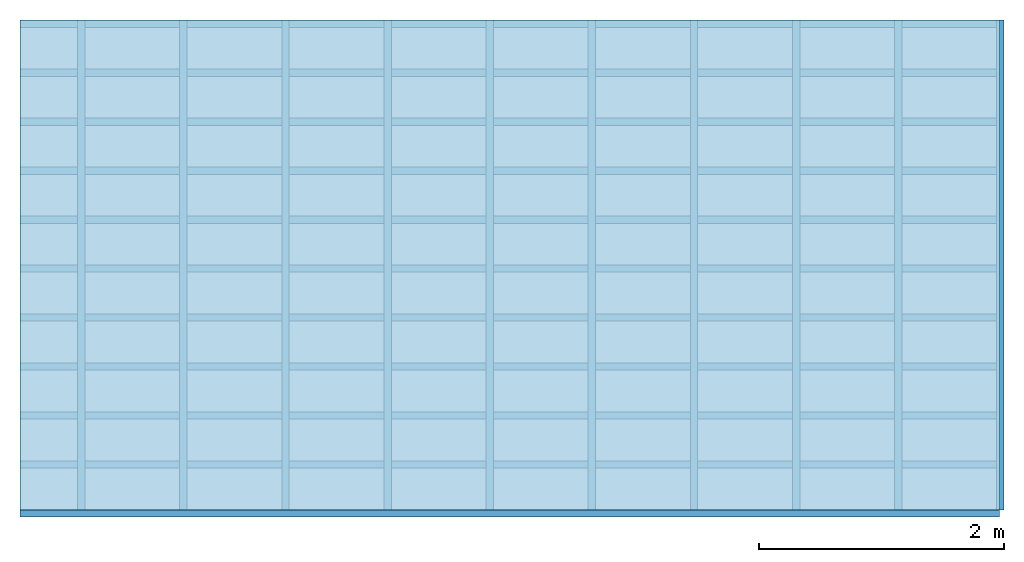
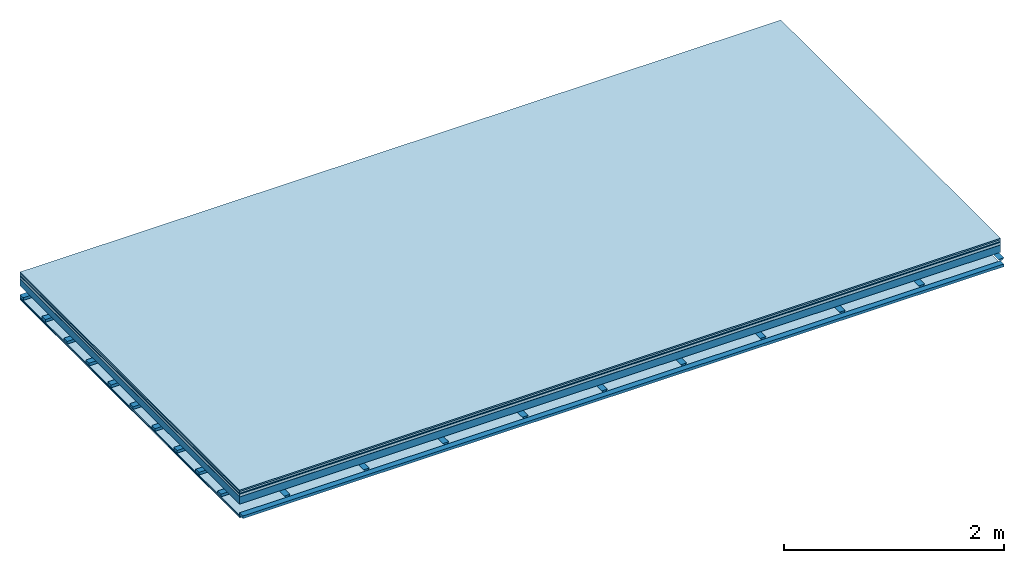
# One storey: 8 plates, 3 members, 1 element without a shape of its own.
"""IFC4 building model written with IfcOpenShell, lengths in metres."""

from ifc_helpers import new_model, si_unit, derived_unit, direction, frame, frame_2d, origin, origin_with_axes, place, context, project, spatial, polyline, rectangle, outline, extrude, material, layer, layer_set, type_object, element, aggregate, save


model = new_model("IFC4")

# Units and contexts
plan_context = context("Plan", 3, precision=1e-05, world=origin(), true_north=direction((0.0, 1.0)))
model_context = context("Model", 3, precision=1e-05, world=origin(), true_north=direction((0.0, 1.0)))
ifc_project = project(units=[si_unit("LENGTHUNIT", "METRE"), derived_unit("SOUNDPRESSUREUNIT", [(si_unit("PRESSUREUNIT", "PASCAL", prefix="MICRO"), 0)]), si_unit("ENERGYUNIT", "JOULE", prefix="MEGA"), si_unit("MASSUNIT", "GRAM", prefix="KILO"), derived_unit("THERMALTRANSMITTANCEUNIT", [(si_unit("POWERUNIT", "WATT"), 1), (si_unit("AREAUNIT", "SQUARE_METRE"), -1), (si_unit("THERMODYNAMICTEMPERATUREUNIT", "KELVIN"), -1)]), derived_unit("AREADENSITYUNIT", [(si_unit("MASSUNIT", "GRAM", prefix="KILO"), 1), (si_unit("AREAUNIT", "SQUARE_METRE"), -1)]), derived_unit("USERDEFINED", [(si_unit("ENERGYUNIT", "JOULE", prefix="MEGA"), 1), (si_unit("AREAUNIT", "SQUARE_METRE"), -1)])], contexts=[plan_context, model_context])

# Site, building, storey
site = spatial("IfcSite", under=ifc_project)
building_placement = place(None, origin())
building = spatial("IfcBuilding", under=site, at=building_placement)
storey_placement = place(building_placement, origin())
storey = spatial("IfcBuildingStorey", under=building, at=storey_placement)

# Slab, members, plates
ifc_material_1 = material(Category="11.013")
ifc_layer_1 = layer(ifc_material_1, 0.015, Name="Flooring")
ifc_material_2 = material(Category="03.007")
ifc_layer_2 = layer(ifc_material_2, 0.02, Name="On-material")
ifc_material_3 = material(Name="Wood fiber generic product", Category="10.009")
ifc_layer_3 = layer(ifc_material_3, 0.01, Name="Impact sound insulation")
ifc_material_4 = material(Name="with broken")
ifc_layer_4 = layer(ifc_material_4, 0.03, Name="on Supporting structure")
ifc_material_5 = material(Name="protection", Category="09.007")
ifc_layer_5 = layer(ifc_material_5, 0.0005, Name="Sub-floor")
ifc_material_6 = material(Name="no composite action")
ifc_layer_6 = layer(ifc_material_6, 0.0, Name="Bond")
ifc_layer_7 = layer(None, 0.08, Name="Supporting structure")
ifc_layer_8 = layer(ifc_material_6, 0.0, Name="Bond")
ifc_layer_9 = layer(None, 0.095, Name="Coupling")
ifc_layer_10 = layer(None, 0.03, Name="Battens / profiles")
ifc_material_7 = material(Name="Plasterboard type A", Category="03.008")
ifc_layer_11 = layer(ifc_material_7, 0.0125, Name="Ceiling covering 1st layer")
ifc_layer_12 = layer(ifc_material_7, 0.0125, Name="Ceiling covering layer 2")
ifc_material_8 = material(Category="04.001")
ifc_layer_13 = layer(ifc_material_8, 0.003, Name="Surface / treatment")
ifc_layer_set = layer_set([ifc_layer_1, ifc_layer_2, ifc_layer_3, ifc_layer_4, ifc_layer_5, ifc_layer_6, ifc_layer_7, ifc_layer_8, ifc_layer_9, ifc_layer_10, ifc_layer_11, ifc_layer_12, ifc_layer_13])
slab_type = type_object("IfcSlabType", Name="A2112", PredefinedType="NOTDEFINED", material=ifc_layer_set)
slab_placement = place(None, frame((0.0, 0.0, 0.0), z_axis=(0.0, 0.0, -1.0), x_axis=(1.0, 0.0, 0.0)))
slab = element("IfcSlab", 1, at=slab_placement, inside=storey, type_object=slab_type, material=ifc_layer_set, Name="Slab #1")
ifc_material_9 = material(Name="Solid timber panel")
member_1_placement = place(slab_placement, origin())
member_1 = element("IfcMember", 2, at=member_1_placement, material=ifc_material_9, Name="Supporting structure", context=plan_context, shape_type="SweptSolid", body=[
    extrude(rectangle(XDim=1.0, YDim=0.08, at=frame_2d((0.5, 0.04), x_axis=(1.0, 0.0))), frame((0.0, 4.0, 0.0755), z_axis=(0.0, -1.0, 0.0), x_axis=(1.0, 0.0, 0.0)), (0.0, 0.0, 1.0), 4.0),
    extrude(rectangle(XDim=1.0, YDim=0.08, at=frame_2d((0.5, 0.04), x_axis=(1.0, 0.0))), frame((1.0, 4.0, 0.0755), z_axis=(0.0, -1.0, 0.0), x_axis=(1.0, 0.0, 0.0)), (0.0, 0.0, 1.0), 4.0),
    extrude(rectangle(XDim=1.0, YDim=0.08, at=frame_2d((0.5, 0.04), x_axis=(1.0, 0.0))), frame((2.0, 4.0, 0.0755), z_axis=(0.0, -1.0, 0.0), x_axis=(1.0, 0.0, 0.0)), (0.0, 0.0, 1.0), 4.0),
    extrude(rectangle(XDim=1.0, YDim=0.08, at=frame_2d((0.5, 0.04), x_axis=(1.0, 0.0))), frame((3.0, 4.0, 0.0755), z_axis=(0.0, -1.0, 0.0), x_axis=(1.0, 0.0, 0.0)), (0.0, 0.0, 1.0), 4.0),
    extrude(rectangle(XDim=1.0, YDim=0.08, at=frame_2d((0.5, 0.04), x_axis=(1.0, 0.0))), frame((4.0, 4.0, 0.0755), z_axis=(0.0, -1.0, 0.0), x_axis=(1.0, 0.0, 0.0)), (0.0, 0.0, 1.0), 4.0),
    extrude(rectangle(XDim=1.0, YDim=0.08, at=frame_2d((0.5, 0.04), x_axis=(1.0, 0.0))), frame((5.0, 4.0, 0.0755), z_axis=(0.0, -1.0, 0.0), x_axis=(1.0, 0.0, 0.0)), (0.0, 0.0, 1.0), 4.0),
    extrude(rectangle(XDim=1.0, YDim=0.08, at=frame_2d((0.5, 0.04), x_axis=(1.0, 0.0))), frame((6.0, 4.0, 0.0755), z_axis=(0.0, -1.0, 0.0), x_axis=(1.0, 0.0, 0.0)), (0.0, 0.0, 1.0), 4.0),
    extrude(rectangle(XDim=1.0, YDim=0.08, at=frame_2d((0.5, 0.04), x_axis=(1.0, 0.0))), frame((7.0, 4.0, 0.0755), z_axis=(0.0, -1.0, 0.0), x_axis=(1.0, 0.0, 0.0)), (0.0, 0.0, 1.0), 4.0),
])
ifc_material_10 = material()
member_2_placement = place(slab_placement, origin())
member_2 = element("IfcMember", 3, at=member_2_placement, material=ifc_material_10, Name="Coupling", context=plan_context, shape_type="SweptSolid", body=[
    extrude(outline(polyline([(0.0, 0.0), (0.06, 0.0), (0.04, 0.02), (0.02, 0.02), (0.0, 0.0)])), frame((0.47, 4.0, 0.2305), z_axis=(0.0, -1.0, 0.0), x_axis=(1.0, 0.0, 0.0)), (0.0, 0.0, 1.0), 4.0),
    extrude(outline(polyline([(0.0, 0.0), (0.06, 0.0), (0.04, 0.02), (0.02, 0.02), (0.0, 0.0)])), frame((1.304, 4.0, 0.2305), z_axis=(0.0, -1.0, 0.0), x_axis=(1.0, 0.0, 0.0)), (0.0, 0.0, 1.0), 4.0),
    extrude(outline(polyline([(0.0, 0.0), (0.06, 0.0), (0.04, 0.02), (0.02, 0.02), (0.0, 0.0)])), frame((2.138, 4.0, 0.2305), z_axis=(0.0, -1.0, 0.0), x_axis=(1.0, 0.0, 0.0)), (0.0, 0.0, 1.0), 4.0),
    extrude(outline(polyline([(0.0, 0.0), (0.06, 0.0), (0.04, 0.02), (0.02, 0.02), (0.0, 0.0)])), frame((2.972, 4.0, 0.2305), z_axis=(0.0, -1.0, 0.0), x_axis=(1.0, 0.0, 0.0)), (0.0, 0.0, 1.0), 4.0),
    extrude(outline(polyline([(0.0, 0.0), (0.06, 0.0), (0.04, 0.02), (0.02, 0.02), (0.0, 0.0)])), frame((3.806, 4.0, 0.2305), z_axis=(0.0, -1.0, 0.0), x_axis=(1.0, 0.0, 0.0)), (0.0, 0.0, 1.0), 4.0),
    extrude(outline(polyline([(0.0, 0.0), (0.06, 0.0), (0.04, 0.02), (0.02, 0.02), (0.0, 0.0)])), frame((4.64, 4.0, 0.2305), z_axis=(0.0, -1.0, 0.0), x_axis=(1.0, 0.0, 0.0)), (0.0, 0.0, 1.0), 4.0),
    extrude(outline(polyline([(0.0, 0.0), (0.06, 0.0), (0.04, 0.02), (0.02, 0.02), (0.0, 0.0)])), frame((5.474, 4.0, 0.2305), z_axis=(0.0, -1.0, 0.0), x_axis=(1.0, 0.0, 0.0)), (0.0, 0.0, 1.0), 4.0),
    extrude(outline(polyline([(0.0, 0.0), (0.06, 0.0), (0.04, 0.02), (0.02, 0.02), (0.0, 0.0)])), frame((6.308, 4.0, 0.2305), z_axis=(0.0, -1.0, 0.0), x_axis=(1.0, 0.0, 0.0)), (0.0, 0.0, 1.0), 4.0),
    extrude(outline(polyline([(0.0, 0.0), (0.06, 0.0), (0.04, 0.02), (0.02, 0.02), (0.0, 0.0)])), frame((7.142, 4.0, 0.2305), z_axis=(0.0, -1.0, 0.0), x_axis=(1.0, 0.0, 0.0)), (0.0, 0.0, 1.0), 4.0),
    extrude(outline(polyline([(0.0, 0.0), (0.06, 0.0), (0.04, 0.02), (0.02, 0.02), (0.0, 0.0)])), frame((7.976, 4.0, 0.2305), z_axis=(0.0, -1.0, 0.0), x_axis=(1.0, 0.0, 0.0)), (0.0, 0.0, 1.0), 4.0),
])
member_3_placement = place(slab_placement, origin())
member_3 = element("IfcMember", 4, at=member_3_placement, material=ifc_material_10, Name="Battens / profiles", context=plan_context, shape_type="SweptSolid", body=[
    extrude(rectangle(XDim=0.06, YDim=0.03, at=frame_2d((0.03, 0.015), x_axis=(1.0, 0.0))), frame((0.0, 0.0, 0.2505), z_axis=(1.0, 0.0, 0.0), x_axis=(0.0, 1.0, 0.0)), (0.0, 0.0, 1.0), 8.0),
    extrude(rectangle(XDim=0.06, YDim=0.03, at=frame_2d((0.03, 0.015), x_axis=(1.0, 0.0))), frame((0.0, 0.4, 0.2505), z_axis=(1.0, 0.0, 0.0), x_axis=(0.0, 1.0, 0.0)), (0.0, 0.0, 1.0), 8.0),
    extrude(rectangle(XDim=0.06, YDim=0.03, at=frame_2d((0.03, 0.015), x_axis=(1.0, 0.0))), frame((0.0, 0.8, 0.2505), z_axis=(1.0, 0.0, 0.0), x_axis=(0.0, 1.0, 0.0)), (0.0, 0.0, 1.0), 8.0),
    extrude(rectangle(XDim=0.06, YDim=0.03, at=frame_2d((0.03, 0.015), x_axis=(1.0, 0.0))), frame((0.0, 1.2, 0.2505), z_axis=(1.0, 0.0, 0.0), x_axis=(0.0, 1.0, 0.0)), (0.0, 0.0, 1.0), 8.0),
    extrude(rectangle(XDim=0.06, YDim=0.03, at=frame_2d((0.03, 0.015), x_axis=(1.0, 0.0))), frame((0.0, 1.6, 0.2505), z_axis=(1.0, 0.0, 0.0), x_axis=(0.0, 1.0, 0.0)), (0.0, 0.0, 1.0), 8.0),
    extrude(rectangle(XDim=0.06, YDim=0.03, at=frame_2d((0.03, 0.015), x_axis=(1.0, 0.0))), frame((0.0, 2.0, 0.2505), z_axis=(1.0, 0.0, 0.0), x_axis=(0.0, 1.0, 0.0)), (0.0, 0.0, 1.0), 8.0),
    extrude(rectangle(XDim=0.06, YDim=0.03, at=frame_2d((0.03, 0.015), x_axis=(1.0, 0.0))), frame((0.0, 2.4, 0.2505), z_axis=(1.0, 0.0, 0.0), x_axis=(0.0, 1.0, 0.0)), (0.0, 0.0, 1.0), 8.0),
    extrude(rectangle(XDim=0.06, YDim=0.03, at=frame_2d((0.03, 0.015), x_axis=(1.0, 0.0))), frame((0.0, 2.8, 0.2505), z_axis=(1.0, 0.0, 0.0), x_axis=(0.0, 1.0, 0.0)), (0.0, 0.0, 1.0), 8.0),
    extrude(rectangle(XDim=0.06, YDim=0.03, at=frame_2d((0.03, 0.015), x_axis=(1.0, 0.0))), frame((0.0, 3.2, 0.2505), z_axis=(1.0, 0.0, 0.0), x_axis=(0.0, 1.0, 0.0)), (0.0, 0.0, 1.0), 8.0),
    extrude(rectangle(XDim=0.06, YDim=0.03, at=frame_2d((0.03, 0.015), x_axis=(1.0, 0.0))), frame((0.0, 3.6, 0.2505), z_axis=(1.0, 0.0, 0.0), x_axis=(0.0, 1.0, 0.0)), (0.0, 0.0, 1.0), 8.0),
    extrude(rectangle(XDim=0.06, YDim=0.03, at=frame_2d((0.03, 0.015), x_axis=(1.0, 0.0))), frame((0.0, 4.0, 0.2505), z_axis=(1.0, 0.0, 0.0), x_axis=(0.0, 1.0, 0.0)), (0.0, 0.0, 1.0), 8.0),
])
plate_1_placement = place(slab_placement, origin())
plate_1 = element("IfcPlate", 5, at=plate_1_placement, material=ifc_material_1, Name="Flooring", context=plan_context, shape_type="SweptSolid", body=[
    extrude(rectangle(XDim=8.0, YDim=4.0, at=frame_2d((4.0, 2.0), x_axis=(1.0, 0.0))), origin_with_axes(), (0.0, 0.0, 1.0), 0.015),
])
plate_2_placement = place(slab_placement, origin())
plate_2 = element("IfcPlate", 6, at=plate_2_placement, material=ifc_material_2, Name="On-material", context=plan_context, shape_type="SweptSolid", body=[
    extrude(rectangle(XDim=8.0, YDim=4.0, at=frame_2d((4.0, 2.0), x_axis=(1.0, 0.0))), frame((0.0, 0.0, 0.015), z_axis=(0.0, 0.0, 1.0), x_axis=(1.0, 0.0, 0.0)), (0.0, 0.0, 1.0), 0.02),
])
plate_3_placement = place(slab_placement, origin())
plate_3 = element("IfcPlate", 7, at=plate_3_placement, material=ifc_material_3, Name="Impact sound insulation", context=plan_context, shape_type="SweptSolid", body=[
    extrude(rectangle(XDim=8.0, YDim=4.0, at=frame_2d((4.0, 2.0), x_axis=(1.0, 0.0))), frame((0.0, 0.0, 0.035), z_axis=(0.0, 0.0, 1.0), x_axis=(1.0, 0.0, 0.0)), (0.0, 0.0, 1.0), 0.01),
])
plate_4_placement = place(slab_placement, origin())
plate_4 = element("IfcPlate", 8, at=plate_4_placement, material=ifc_material_4, Name="on Supporting structure", context=plan_context, shape_type="SweptSolid", body=[
    extrude(rectangle(XDim=8.0, YDim=4.0, at=frame_2d((4.0, 2.0), x_axis=(1.0, 0.0))), frame((0.0, 0.0, 0.045), z_axis=(0.0, 0.0, 1.0), x_axis=(1.0, 0.0, 0.0)), (0.0, 0.0, 1.0), 0.03),
])
plate_5_placement = place(slab_placement, origin())
plate_5 = element("IfcPlate", 9, at=plate_5_placement, material=ifc_material_5, Name="Sub-floor", context=plan_context, shape_type="SweptSolid", body=[
    extrude(rectangle(XDim=8.0, YDim=4.0, at=frame_2d((4.0, 2.0), x_axis=(1.0, 0.0))), frame((0.0, 0.0, 0.075), z_axis=(0.0, 0.0, 1.0), x_axis=(1.0, 0.0, 0.0)), (0.0, 0.0, 1.0), 0.0005),
])
plate_6_placement = place(slab_placement, origin())
plate_6 = element("IfcPlate", 10, at=plate_6_placement, material=ifc_material_7, Name="Ceiling covering 1st layer", context=plan_context, shape_type="SweptSolid", body=[
    extrude(rectangle(XDim=8.0, YDim=4.0, at=frame_2d((4.0, 2.0), x_axis=(1.0, 0.0))), frame((0.0, 0.0, 0.2805), z_axis=(0.0, 0.0, 1.0), x_axis=(1.0, 0.0, 0.0)), (0.0, 0.0, 1.0), 0.0125),
])
plate_7_placement = place(slab_placement, origin())
plate_7 = element("IfcPlate", 11, at=plate_7_placement, material=ifc_material_7, Name="Ceiling covering layer 2", context=plan_context, shape_type="SweptSolid", body=[
    extrude(rectangle(XDim=8.0, YDim=4.0, at=frame_2d((4.0, 2.0), x_axis=(1.0, 0.0))), frame((0.0, 0.0, 0.293), z_axis=(0.0, 0.0, 1.0), x_axis=(1.0, 0.0, 0.0)), (0.0, 0.0, 1.0), 0.0125),
])
plate_8_placement = place(slab_placement, origin())
plate_8 = element("IfcPlate", 12, at=plate_8_placement, material=ifc_material_8, Name="Surface / treatment", context=plan_context, shape_type="SweptSolid", body=[
    extrude(rectangle(XDim=8.0, YDim=4.0, at=frame_2d((4.0, 2.0), x_axis=(1.0, 0.0))), frame((0.0, 0.0, 0.3055), z_axis=(0.0, 0.0, 1.0), x_axis=(1.0, 0.0, 0.0)), (0.0, 0.0, 1.0), 0.003),
])
aggregate(slab, [plate_1, plate_2, plate_3, plate_4, plate_5, member_1, member_2, member_3, plate_6, plate_7, plate_8])

save(model, "model.ifc")
